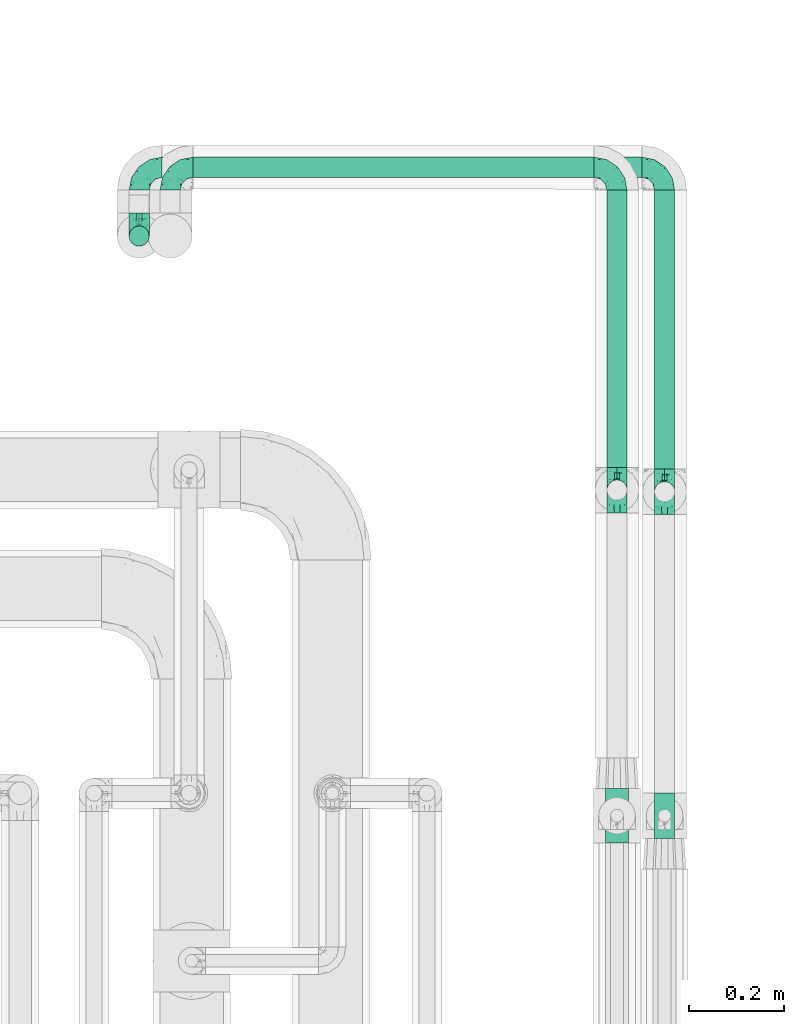
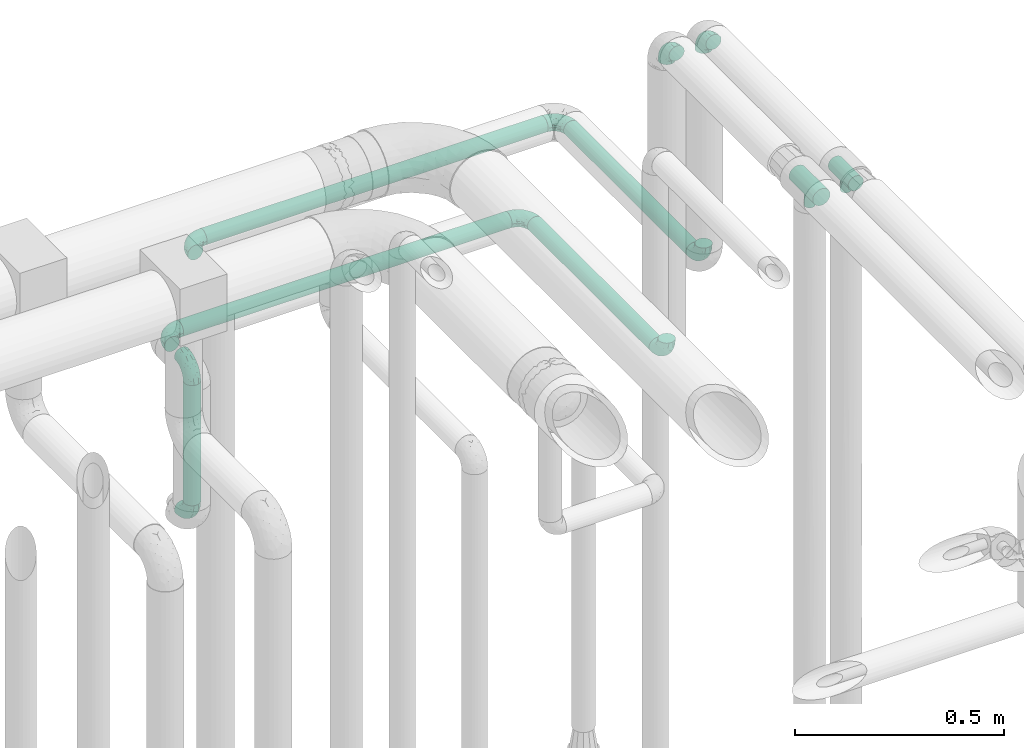
# One storey, part 727 of 827: 12 flow fittings, 5 flow segments.
"""IFC2X3 building model written with IfcOpenShell, lengths in millimetres."""

from ifc_helpers import new_model, entity, si_unit, converted_unit, derived_unit, direction, frame, origin, origin_2d_with_axis, place, context, subcontext, project, spatial, circle, extrude, faceted_brep, source, transform, mapped, material, type_object, type_shapes, element, save


model = new_model("IFC2X3")

# Units and contexts
model_context = context("Model", 3, precision=0.01, world=origin(), true_north=direction((6.12303176911189e-17, 1.0)))
body_context = subcontext(model_context, "Body", "Model", "MODEL_VIEW")
ifc_project = project(units=[si_unit("LENGTHUNIT", "METRE", prefix="MILLI"), si_unit("AREAUNIT", "SQUARE_METRE"), si_unit("VOLUMEUNIT", "CUBIC_METRE"), converted_unit("PLANEANGLEUNIT", "DEGREE", entity("IfcRatioMeasure", 0.0174532925199433), si_unit("PLANEANGLEUNIT", "RADIAN"), dimensions=[0, 0, 0, 0, 0, 0, 0]), si_unit("MASSUNIT", "GRAM", prefix="KILO"), derived_unit("MASSDENSITYUNIT", [(si_unit("MASSUNIT", "GRAM", prefix="KILO"), 1), (si_unit("LENGTHUNIT", "METRE"), -3)]), derived_unit("MOMENTOFINERTIAUNIT", [(si_unit("LENGTHUNIT", "METRE"), 4)]), si_unit("TIMEUNIT", "SECOND"), si_unit("FREQUENCYUNIT", "HERTZ"), si_unit("THERMODYNAMICTEMPERATUREUNIT", "DEGREE_CELSIUS"), derived_unit("THERMALTRANSMITTANCEUNIT", [(si_unit("MASSUNIT", "GRAM", prefix="KILO"), 1), (si_unit("THERMODYNAMICTEMPERATUREUNIT", "KELVIN"), -1), (si_unit("TIMEUNIT", "SECOND"), -3)]), derived_unit("VOLUMETRICFLOWRATEUNIT", [(si_unit("LENGTHUNIT", "METRE"), 3), (si_unit("TIMEUNIT", "SECOND"), -1)]), derived_unit("MASSFLOWRATEUNIT", [(si_unit("MASSUNIT", "GRAM", prefix="KILO"), 1), (si_unit("TIMEUNIT", "SECOND"), -1)]), derived_unit("ROTATIONALFREQUENCYUNIT", [(si_unit("TIMEUNIT", "SECOND"), -1)]), si_unit("ELECTRICCURRENTUNIT", "AMPERE"), si_unit("ELECTRICVOLTAGEUNIT", "VOLT"), si_unit("POWERUNIT", "WATT"), si_unit("FORCEUNIT", "NEWTON", prefix="KILO"), si_unit("ILLUMINANCEUNIT", "LUX"), si_unit("LUMINOUSFLUXUNIT", "LUMEN"), si_unit("LUMINOUSINTENSITYUNIT", "CANDELA"), derived_unit("USERDEFINED", [(si_unit("MASSUNIT", "GRAM", prefix="KILO"), -1), (si_unit("LENGTHUNIT", "METRE"), -2), (si_unit("TIMEUNIT", "SECOND"), 3), (si_unit("LUMINOUSFLUXUNIT", "LUMEN"), 1)]), derived_unit("LINEARVELOCITYUNIT", [(si_unit("LENGTHUNIT", "METRE"), 1), (si_unit("TIMEUNIT", "SECOND"), -1)]), si_unit("PRESSUREUNIT", "PASCAL"), derived_unit("USERDEFINED", [(si_unit("LENGTHUNIT", "METRE"), -2), (si_unit("MASSUNIT", "GRAM", prefix="KILO"), 1), (si_unit("TIMEUNIT", "SECOND"), -2)]), derived_unit("LINEARFORCEUNIT", [(si_unit("MASSUNIT", "GRAM", prefix="KILO"), 1), (si_unit("LENGTHUNIT", "METRE"), 1), (si_unit("TIMEUNIT", "SECOND"), -2), (si_unit("LENGTHUNIT", "METRE"), -1)]), derived_unit("PLANARFORCEUNIT", [(si_unit("MASSUNIT", "GRAM", prefix="KILO"), 1), (si_unit("LENGTHUNIT", "METRE"), 1), (si_unit("TIMEUNIT", "SECOND"), -2), (si_unit("LENGTHUNIT", "METRE"), -2)])], contexts=[model_context])

# Site, building, storey
site_placement = place(None, origin())
site = spatial("IfcSite", under=ifc_project, at=site_placement, CompositionType="ELEMENT")
building_placement = place(site_placement, origin())
building = spatial("IfcBuilding", under=site, at=building_placement, CompositionType="ELEMENT")
storey_placement = place(building_placement, frame((0.0, 0.0, 28200.0)))
storey = spatial("IfcBuildingStorey", under=building, at=storey_placement, Name="08", CompositionType="ELEMENT", Elevation=28200.0)

# Flow segments
pipe_segment_type = type_object("IfcPipeSegmentType", PredefinedType="NOTDEFINED")
flow_segment_1_placement = place(storey_placement, frame((60025.43, 18648.72, 1689.87)))
element("IfcFlowSegment", 1, at=flow_segment_1_placement, inside=storey, type_object=pipe_segment_type, context=body_context, shape_type="SweptSolid", body=[
    extrude(circle(Radius=21.15, at=origin_2d_with_axis()), frame((22.75, 22.75, 0.0), z_axis=(0.0, 0.0, 1.0), x_axis=(-1.0, 0.0, 0.0)), (0.0, 0.0, 1.0), 351.500000000011),
])
flow_segment_2_placement = place(storey_placement, frame((61029.89, 18185.33, 2066.63)))
element("IfcFlowSegment", 2, at=flow_segment_2_placement, inside=storey, type_object=pipe_segment_type, context=body_context, shape_type="SweptSolid", body=[
    extrude(circle(Radius=21.15, at=origin_2d_with_axis()), frame((22.75, 0.0, 22.75), z_axis=(0.0, 1.0, 0.0), x_axis=(1.0, 0.0, 0.0)), (0.0, 0.0, 1.0), 582.616004091366),
])
flow_segment_3_placement = place(storey_placement, frame((60161.17, 18793.35, 2312.0)))
element("IfcFlowSegment", 3, at=flow_segment_3_placement, inside=storey, type_object=pipe_segment_type, context=body_context, shape_type="SweptSolid", body=[
    extrude(circle(Radius=21.15, at=origin_2d_with_axis()), frame((0.0, 22.75, 22.75), z_axis=(1.0, 0.0, 0.0), x_axis=(0.0, 1.0, 0.0)), (0.0, 0.0, 1.0), 943.465172144308),
])
flow_segment_4_placement = place(storey_placement, frame((60096.17, 18793.2, 2066.63)))
element("IfcFlowSegment", 4, at=flow_segment_4_placement, inside=storey, type_object=pipe_segment_type, context=body_context, shape_type="SweptSolid", body=[
    extrude(circle(Radius=21.15, at=origin_2d_with_axis()), frame((0.0, 22.89, 22.75), z_axis=(0.999999986826571, -0.000162317151743365, 0.0), x_axis=(0.000162317151743365, 0.999999986826571, 0.0)), (0.0, 0.0, 1.0), 908.465194111927),
])
flow_segment_5_placement = place(storey_placement, frame((61129.89, 18181.83, 2312.0)))
element("IfcFlowSegment", 5, at=flow_segment_5_placement, inside=storey, type_object=pipe_segment_type, context=body_context, shape_type="SweptSolid", body=[
    extrude(circle(Radius=21.15, at=origin_2d_with_axis()), frame((22.75, 0.0, 22.75), z_axis=(0.0, 1.0, 0.0), x_axis=(1.0, 0.0, 0.0)), (0.0, 0.0, 1.0), 586.263463574079),
])

# Flow fittings
ifc_material = material()
pipe_fitting_type_1 = type_object("IfcPipeFittingType", Name="ADSK_1", PredefinedType="NOTDEFINED", material=ifc_material)
shared_shape_1 = source(origin(), body_context, "Body", "Brep", [
    faceted_brep([(-48.0, 10.6, -18.36), (-48.0, 5.49, -20.48), (-48.0, 0.0, -21.2), (-48.0, -5.49, -20.48), (-48.0, -10.6, -18.36), (-48.0, -14.99, -14.99), (-48.0, -18.36, -10.6), (-48.0, -20.48, -5.49), (-48.0, -21.2, 0.0), (-48.0, -20.48, 5.49), (-48.0, -18.36, 10.6), (-48.0, -14.99, 14.99), (-48.0, -10.6, 18.36), (-48.0, -5.49, 20.48), (-48.0, 0.0, 21.2), (-48.0, 5.49, 20.48), (-48.0, 10.6, 18.36), (-48.0, 14.99, 14.99), (-48.0, 18.36, 10.6), (-48.0, 20.48, 5.49), (-48.0, 21.2, 0.0), (-48.0, 20.48, -5.49), (-48.0, 18.36, -10.6), (-48.0, 14.99, -14.99), (0.0, 48.0, -21.2), (-5.49, 48.0, -20.48), (-10.6, 48.0, -18.36), (-14.99, 48.0, -14.99), (-18.36, 48.0, -10.6), (-20.48, 48.0, -5.49), (-21.2, 48.0, 0.0), (-20.48, 48.0, 5.49), (-18.36, 48.0, 10.6), (-14.99, 48.0, 14.99), (-10.6, 48.0, 18.36), (-5.49, 48.0, 20.48), (0.0, 48.0, 21.2), (5.49, 48.0, 20.48), (10.6, 48.0, 18.36), (14.99, 48.0, 14.99), (18.36, 48.0, 10.6), (20.48, 48.0, 5.49), (21.2, 48.0, 0.0), (20.48, 48.0, -5.49), (18.36, 48.0, -10.6), (14.99, 48.0, -14.99), (10.6, 48.0, -18.36), (5.49, 48.0, -20.48), (-35.25, -16.22, 12.01), (-34.76, -18.57, 0.0), (-20.87, -12.37, 10.9), (-31.49, -11.78, 15.9), (-37.0, -2.58, 20.86), (-33.89, 3.62, 21.15), (-31.81, -18.14, 6.76), (-5.78, 5.78, 17.67), (-19.42, -4.1, 17.86), (-9.6, -3.39, 13.73), (-35.44, -7.73, 19.13), (11.78, 31.49, 15.9), (-5.93, -5.46, 6.95), (-18.45, -13.78, 5.46), (-10.29, -8.43, 0.0), (-24.6, 0.55, 20.62), (-37.28, 17.94, 13.81), (-33.38, 22.85, 9.59), (-41.46, 20.06, 8.75), (-29.51, 20.45, 15.16), (-15.04, 10.79, 21.13), (-7.08, 16.98, 20.93), (-8.39, 23.51, 21.15), (-40.86, 13.03, 17.26), (-8.05, 41.26, 19.83), (-3.21, 35.97, 21.14), (8.53, 19.66, 14.74), (4.1, 19.42, 17.86), (-37.72, 22.66, 4.78), (-37.07, 8.58, 19.98), (-13.0, 5.43, 19.97), (-3.78, 13.93, 19.7), (3.02, 8.69, 13.43), (-2.27, -0.05, 10.65), (6.22, 6.99, 7.09), (-22.25, 34.6, 9.45), (18.14, 31.81, 6.76), (16.22, 35.25, 12.01), (12.37, 20.87, 10.9), (7.73, 35.44, 19.13), (-21.52, -15.93, 0.0), (2.58, 37.0, 20.86), (18.57, 34.76, 0.0), (13.78, 18.45, 5.46), (15.93, 21.52, 0.0), (-20.03, -8.54, 14.9), (-28.6, 28.6, 5.16), (-24.79, 34.6, 0.0), (-34.6, 24.79, 0.0), (-22.81, 37.41, 4.68), (-23.36, 26.33, 14.79), (-13.68, 37.05, 17.49), (-17.72, 38.12, 13.73), (-26.25, 27.3, 11.24), (-9.71, 32.34, 20.14), (-17.26, 25.6, 18.71), (-26.33, 9.99, 20.77), (-24.06, 6.05, 21.2), (-25.02, 15.46, 19.56), (-24.3, 20.72, 17.57), (-31.95, 15.23, 17.8), (-13.53, 24.7, 20.21), (-17.6, 17.6, 20.6), (-0.55, 24.6, 20.62), (-11.41, -7.48, 10.43), (0.93, -0.93, 0.0), (8.43, 10.29, 0.0), (-11.41, -7.48, -10.43), (-20.1, -8.84, -14.66), (-9.6, -3.39, -13.73), (7.73, 35.44, -19.13), (4.1, 19.42, -17.86), (-0.55, 24.6, -20.62), (-38.12, 17.72, -13.73), (-37.05, 13.68, -17.49), (-32.34, 9.71, -20.14), (-41.26, 8.05, -19.83), (-37.41, 22.81, -4.68), (-23.51, 8.39, -21.15), (-35.97, 3.21, -21.14), (-28.6, 28.6, -5.16), (-31.81, -18.14, -6.76), (-18.45, -13.78, -5.46), (-25.6, 17.26, -18.71), (-19.42, -4.1, -17.86), (-17.94, 37.28, -13.81), (-22.85, 33.38, -9.59), (-20.06, 41.46, -8.75), (-31.49, -11.78, -15.9), (-35.25, -16.22, -12.01), (8.53, 19.66, -14.74), (11.78, 31.49, -15.9), (-9.99, 26.33, -20.77), (-6.05, 24.06, -21.2), (-10.79, 15.04, -21.13), (-37.0, -2.58, -20.86), (-16.98, 7.08, -20.93), (-5.43, 13.0, -19.97), (-13.93, 3.78, -19.7), (-20.87, -12.37, -10.9), (-26.33, 23.36, -14.79), (-22.66, 37.72, -4.78), (13.78, 18.45, -5.46), (18.14, 31.81, -6.76), (-15.46, 25.02, -19.56), (-20.72, 24.3, -17.57), (16.22, 35.25, -12.01), (-13.03, 40.86, -17.26), (-8.58, 37.07, -19.98), (2.58, 37.0, -20.86), (-3.62, 33.89, -21.15), (-34.6, 22.25, -9.45), (6.22, 6.99, -7.09), (-20.45, 29.51, -15.16), (-35.44, -7.73, -19.13), (12.37, 20.87, -10.9), (-27.3, 26.25, -11.24), (-15.23, 31.95, -17.8), (-24.7, 13.53, -20.21), (-24.6, 0.55, -20.62), (-5.78, 5.78, -17.67), (-17.6, 17.6, -20.6), (3.02, 8.69, -13.43), (-5.93, -5.46, -6.95), (-2.27, -0.05, -10.65)], [[[0, 1, 2, 3, 4, 5, 6, 7, 8, 9, 10, 11, 12, 13, 14, 15, 16, 17, 18, 19, 20, 21, 22, 23]], [[24, 25, 26, 27, 28, 29, 30, 31, 32, 33, 34, 35, 36, 37, 38, 39, 40, 41, 42, 43, 44, 45, 46, 47]], [[10, 48, 11]], [[9, 8, 49]], [[48, 50, 51]], [[14, 52, 53]], [[10, 54, 48]], [[9, 54, 10]], [[55, 56, 57]], [[51, 12, 11]], [[51, 58, 12]], [[59, 39, 38]], [[60, 61, 62]], [[58, 56, 63]], [[64, 65, 66]], [[67, 65, 64]], [[68, 69, 70]], [[16, 71, 17]], [[13, 52, 14]], [[35, 72, 73]], [[14, 53, 15]], [[17, 64, 18]], [[74, 59, 75]], [[20, 19, 76]], [[66, 19, 18]], [[77, 15, 53]], [[15, 77, 16]], [[69, 78, 79]], [[80, 81, 82]], [[32, 31, 83]], [[84, 85, 86]], [[59, 87, 75]], [[61, 54, 88]], [[36, 89, 37]], [[84, 41, 40]], [[36, 35, 73]], [[90, 41, 84]], [[40, 39, 85]], [[12, 58, 13]], [[85, 84, 40]], [[91, 84, 86]], [[84, 92, 90]], [[87, 38, 37]], [[93, 56, 51]], [[65, 94, 76]], [[94, 95, 96]], [[84, 91, 92]], [[95, 97, 30]], [[98, 99, 100]], [[76, 94, 96]], [[101, 98, 83]], [[100, 99, 33]], [[102, 70, 73]], [[103, 102, 99]], [[94, 97, 95]], [[72, 99, 102]], [[72, 35, 34]], [[34, 33, 99]], [[9, 49, 54]], [[87, 59, 38]], [[104, 105, 68]], [[106, 103, 107]], [[106, 77, 104]], [[71, 64, 17]], [[108, 107, 67]], [[33, 32, 100]], [[109, 103, 110]], [[102, 109, 70]], [[89, 73, 111]], [[50, 48, 54]], [[51, 11, 48]], [[56, 58, 51]], [[88, 54, 49]], [[52, 58, 63]], [[50, 112, 93]], [[56, 55, 78]], [[39, 59, 85]], [[86, 85, 59]], [[89, 87, 37]], [[42, 41, 90]], [[111, 79, 75]], [[111, 75, 87]], [[75, 55, 80]], [[104, 77, 53]], [[71, 77, 108]], [[32, 83, 100]], [[98, 100, 83]], [[99, 98, 103]], [[106, 107, 108]], [[68, 70, 110]], [[111, 73, 70]], [[68, 110, 104]], [[68, 63, 78]], [[57, 93, 112]], [[80, 55, 57]], [[61, 50, 54]], [[80, 82, 86]], [[81, 57, 112]], [[74, 86, 59]], [[60, 113, 82]], [[82, 114, 91]], [[101, 94, 65]], [[97, 94, 83]], [[73, 89, 36]], [[87, 89, 111]], [[58, 52, 13]], [[53, 52, 63]], [[104, 53, 105]], [[106, 104, 110]], [[20, 76, 96]], [[76, 19, 66]], [[103, 106, 110]], [[77, 106, 108]], [[103, 98, 107]], [[67, 107, 98]], [[67, 98, 101]], [[108, 67, 64]], [[53, 63, 105]], [[63, 68, 105]], [[83, 31, 97]], [[30, 97, 31]], [[62, 113, 60]], [[112, 61, 60]], [[61, 88, 62]], [[86, 82, 91]], [[56, 78, 63]], [[114, 82, 113]], [[114, 92, 91]], [[79, 78, 55]], [[75, 79, 55]], [[69, 79, 111]], [[70, 69, 111]], [[78, 69, 68]], [[77, 71, 16]], [[64, 71, 108]], [[64, 66, 18]], [[76, 66, 65]], [[99, 72, 34]], [[73, 72, 102]], [[94, 101, 83]], [[67, 101, 65]], [[75, 80, 74]], [[80, 86, 74]], [[70, 109, 110]], [[102, 103, 109]], [[50, 93, 51]], [[57, 56, 93]], [[61, 112, 50]], [[81, 112, 60]], [[82, 81, 60]], [[80, 57, 81]], [[115, 116, 117]], [[118, 119, 120]], [[121, 122, 23]], [[123, 124, 122]], [[96, 125, 20]], [[123, 126, 127]], [[128, 96, 95]], [[129, 130, 88]], [[123, 122, 131]], [[116, 132, 117]], [[133, 134, 135]], [[0, 124, 1]], [[5, 136, 137]], [[138, 119, 139]], [[129, 88, 49]], [[140, 141, 142]], [[6, 5, 137]], [[46, 118, 47]], [[143, 3, 2]], [[144, 145, 146]], [[6, 129, 7]], [[129, 137, 147]], [[127, 2, 1]], [[148, 122, 121]], [[128, 125, 96]], [[134, 128, 149]], [[95, 149, 128]], [[150, 151, 92]], [[30, 29, 149]], [[152, 131, 153]], [[27, 133, 28]], [[154, 45, 44]], [[136, 5, 4]], [[27, 26, 155]], [[156, 26, 25]], [[24, 157, 158]], [[24, 47, 157]], [[22, 21, 159]], [[160, 150, 114]], [[134, 133, 161]], [[142, 144, 126]], [[46, 139, 118]], [[162, 136, 4]], [[156, 25, 158]], [[1, 124, 127]], [[115, 147, 116]], [[45, 154, 139]], [[139, 46, 45]], [[154, 163, 139]], [[162, 4, 3]], [[42, 90, 43]], [[130, 129, 147]], [[49, 7, 129]], [[43, 151, 44]], [[0, 23, 122]], [[24, 158, 25]], [[136, 162, 132]], [[135, 29, 28]], [[43, 90, 151]], [[164, 148, 159]], [[152, 156, 140]], [[155, 133, 27]], [[165, 153, 161]], [[23, 22, 121]], [[123, 131, 166]], [[123, 166, 126]], [[143, 127, 167]], [[147, 137, 136]], [[8, 7, 49]], [[129, 6, 137]], [[143, 162, 3]], [[167, 146, 132]], [[167, 132, 162]], [[132, 168, 117]], [[44, 151, 154]], [[92, 151, 90]], [[163, 154, 151]], [[119, 118, 139]], [[157, 118, 120]], [[138, 139, 163]], [[119, 168, 145]], [[140, 156, 158]], [[155, 156, 165]], [[22, 159, 121]], [[148, 121, 159]], [[122, 148, 131]], [[152, 153, 165]], [[142, 126, 169]], [[167, 127, 126]], [[142, 169, 140]], [[142, 120, 145]], [[168, 170, 117]], [[160, 171, 172]], [[115, 172, 171]], [[171, 62, 130]], [[119, 170, 168]], [[170, 163, 160]], [[150, 163, 151]], [[113, 171, 160]], [[164, 128, 134]], [[125, 128, 159]], [[127, 143, 2]], [[162, 143, 167]], [[118, 157, 47]], [[158, 157, 120]], [[140, 158, 141]], [[152, 140, 169]], [[30, 149, 95]], [[149, 29, 135]], [[131, 152, 169]], [[156, 152, 165]], [[131, 148, 153]], [[161, 153, 148]], [[161, 148, 164]], [[165, 161, 133]], [[158, 120, 141]], [[120, 142, 141]], [[159, 21, 125]], [[20, 125, 21]], [[115, 130, 147]], [[114, 113, 160]], [[62, 171, 113]], [[62, 88, 130]], [[160, 163, 150]], [[150, 92, 114]], [[119, 145, 120]], [[146, 145, 168]], [[132, 146, 168]], [[144, 146, 167]], [[126, 144, 167]], [[145, 144, 142]], [[156, 155, 26]], [[133, 155, 165]], [[133, 135, 28]], [[149, 135, 134]], [[122, 124, 0]], [[127, 124, 123]], [[128, 164, 159]], [[161, 164, 134]], [[163, 170, 138]], [[170, 119, 138]], [[131, 169, 166]], [[126, 166, 169]], [[147, 136, 116]], [[132, 116, 136]], [[172, 115, 117]], [[130, 115, 171]], [[117, 170, 172]], [[160, 172, 170]]]),
])
type_shapes(pipe_fitting_type_1, [shared_shape_1])
for number, where, z_axis, x_axis, name in (
    (6, (60113.17, 18816.1, 2334.74), (0.0, 0.0, 1.0), (-1.0, 0.0, 0.0), "ADSK_1"),
    (7, (60048.17, 18671.47, 1641.87), (-1.0, 0.0, 0.0), (0.0, -1.0, 0.0), "ADSK_1"),
    (8, (60048.17, 18671.47, 2089.37), (-1.0, 0.0, 0.0), (0.0, 0.0, 1.0), "ADSK_1"),
    (9, (60048.17, 18816.1, 2089.37), (0.0, 0.0, 1.0), (-1.0, 0.0, 0.0), "ADSK_1"),
    (10, (61052.64, 18137.33, 2999.74), (-1.0, 0.0, 0.0), (0.0, 1.0, 0.0), "ADSK_1"),
    (11, (61052.64, 18137.33, 2089.37), (1.0, 0.0, 0.0), (0.0, 0.0, -1.0), "ADSK_1"),
    (12, (61052.64, 18815.95, 2089.37), (0.0, 0.0, 1.0), (0.0, 1.0, 0.0), "ADSK_1"),
    (13, (61152.64, 18133.83, 2999.74), (-1.0, 0.0, 0.0), (0.0, 1.0, 0.0), "ADSK_1"),
    (14, (61152.64, 18133.83, 2334.74), (1.0, 0.0, 0.0), (0.0, 0.0, -1.0), "ADSK_1"),
    (15, (61152.64, 18816.1, 2334.74), (0.0, 0.0, 1.0), (0.0, 1.0, 0.0), "ADSK_1"),
):
    element("IfcFlowFitting", number, at=place(storey_placement, frame(where, z_axis=z_axis, x_axis=x_axis)), inside=storey, type_object=pipe_fitting_type_1, material=ifc_material, Name=name, ObjectType="ADSK_1", context=body_context, shape_type="MappedRepresentation", body=[
        mapped(shared_shape_1, transform((0.0, 0.0, 0.0), scale=1.0)),
    ])
pipe_fitting_type_2 = type_object("IfcPipeFittingType", Name="ADSK_1", PredefinedType="NOTDEFINED", material=ifc_material)
shared_shape_2 = source(origin(), body_context, "Body", "Brep", [
    faceted_brep([(-48.0, 10.6, -18.36), (-48.0, 5.49, -20.48), (-48.0, 0.0, -21.2), (-48.0, -5.49, -20.48), (-48.0, -10.6, -18.36), (-48.0, -14.99, -14.99), (-48.0, -18.36, -10.6), (-48.0, -20.48, -5.49), (-48.0, -21.2, 0.0), (-48.0, -20.48, 5.49), (-48.0, -18.36, 10.6), (-48.0, -14.99, 14.99), (-48.0, -10.6, 18.36), (-48.0, -5.49, 20.48), (-48.0, 0.0, 21.2), (-48.0, 5.49, 20.48), (-48.0, 10.6, 18.36), (-48.0, 14.99, 14.99), (-48.0, 18.36, 10.6), (-48.0, 20.48, 5.49), (-48.0, 21.2, 0.0), (-48.0, 20.48, -5.49), (-48.0, 18.36, -10.6), (-48.0, 14.99, -14.99), (48.0, 0.0, -21.2), (48.0, 5.49, -20.48), (48.0, 10.6, -18.36), (48.0, 14.99, -14.99), (48.0, 18.36, -10.6), (48.0, 20.48, -5.49), (48.0, 21.2, 0.0), (48.0, 20.48, 5.49), (48.0, 18.36, 10.6), (48.0, 14.99, 14.99), (48.0, 10.6, 18.36), (48.0, 5.49, 20.48), (48.0, 0.0, 21.2), (48.0, -5.49, 20.48), (48.0, -10.6, 18.36), (48.0, -14.99, 14.99), (48.0, -18.36, 10.6), (48.0, -20.48, 5.49), (48.0, -21.2, 0.0), (48.0, -20.48, -5.49), (48.0, -18.36, -10.6), (48.0, -14.99, -14.99), (48.0, -10.6, -18.36), (48.0, -5.49, -20.48), (12.6, -20.67, 4.7), (13.03, -20.94, 2.35), (13.45, -21.2, 0.0), (10.26, -19.33, 8.7), (2.4, -16.56, 13.23), (6.78, -17.73, 11.62), (4.59, -17.15, 12.42), (-13.45, -21.2, 0.0), (-13.03, -20.94, 2.35), (-12.6, -20.67, 4.7), (-10.26, -19.34, 8.69), (-6.78, -17.74, 11.61), (-2.4, -16.56, 13.23), (0.0, -16.56, 13.23), (2.4, -16.56, -13.23), (6.78, -17.73, -11.62), (4.59, -17.15, -12.42), (10.26, -19.33, -8.7), (12.6, -20.67, -4.7), (13.03, -20.94, -2.35), (-2.4, -16.56, -13.23), (-6.78, -17.74, -11.61), (-10.26, -19.34, -8.69), (0.0, -16.56, -13.23), (-12.6, -20.67, -4.7), (-13.03, -20.94, -2.35), (3.48, -48.0, -12.99), (6.73, -48.0, -11.65), (9.51, -48.0, -9.51), (11.65, -48.0, -6.73), (12.99, -48.0, -3.48), (13.45, -48.0, 0.0), (12.99, -48.0, 3.48), (11.65, -48.0, 6.72), (9.51, -48.0, 9.51), (6.73, -48.0, 11.65), (3.48, -48.0, 12.99), (0.0, -48.0, 13.45), (-3.48, -48.0, 12.99), (-6.72, -48.0, 11.65), (-9.51, -48.0, 9.51), (-11.65, -48.0, 6.72), (-12.99, -48.0, 3.48), (-13.45, -48.0, 0.0), (-12.99, -48.0, -3.48), (-11.65, -48.0, -6.73), (-9.51, -48.0, -9.51), (-6.72, -48.0, -11.65), (-3.48, -48.0, -12.99), (0.0, -48.0, -13.45)], [[[0, 1, 2, 3, 4, 5, 6, 7, 8, 9, 10, 11, 12, 13, 14, 15, 16, 17, 18, 19, 20, 21, 22, 23]], [[24, 25, 26, 27, 28, 29, 30, 31, 32, 33, 34, 35, 36, 37, 38, 39, 40, 41, 42, 43, 44, 45, 46, 47]], [[42, 41, 48]], [[42, 48, 49, 50]], [[41, 51, 48]], [[40, 39, 52]], [[53, 51, 40]], [[40, 52, 54, 53]], [[39, 11, 52]], [[40, 51, 41]], [[8, 55, 56, 57]], [[9, 8, 57]], [[57, 58, 9]], [[59, 60, 10]], [[59, 10, 58]], [[10, 60, 11]], [[58, 10, 9]], [[11, 60, 61, 52]], [[39, 38, 12, 11]], [[14, 13, 37, 36]], [[13, 12, 38, 37]], [[15, 14, 36, 35]], [[32, 31, 19, 18]], [[17, 16, 34, 33]], [[18, 17, 33, 32]], [[35, 34, 16, 15]], [[20, 19, 31, 30]], [[29, 28, 22, 21]], [[28, 27, 23, 22]], [[30, 29, 21, 20]], [[24, 47, 3, 2]], [[25, 1, 0, 26]], [[2, 1, 25, 24]], [[26, 0, 23, 27]], [[4, 3, 47, 46]], [[46, 45, 5, 4]], [[45, 44, 62]], [[44, 63, 64, 62]], [[44, 65, 63]], [[45, 62, 5]], [[43, 42, 66]], [[66, 65, 43]], [[42, 50, 67, 66]], [[43, 65, 44]], [[68, 69, 6]], [[6, 5, 68]], [[69, 70, 6]], [[5, 62, 71, 68]], [[70, 72, 7]], [[72, 8, 7]], [[8, 72, 73, 55]], [[70, 7, 6]], [[74, 75, 76, 77, 78, 79, 80, 81, 82, 83, 84, 85, 86, 87, 88, 89, 90, 91, 92, 93, 94, 95, 96, 97]], [[85, 60, 86]], [[59, 88, 87]], [[88, 58, 89]], [[59, 87, 86]], [[56, 55, 91]], [[91, 90, 56]], [[90, 89, 57]], [[90, 57, 56]], [[58, 57, 89]], [[88, 59, 58]], [[49, 79, 50]], [[86, 60, 59]], [[85, 52, 61, 60]], [[83, 53, 54]], [[82, 53, 83]], [[48, 81, 80]], [[82, 81, 51]], [[52, 85, 84]], [[54, 52, 84]], [[83, 54, 84]], [[53, 82, 51]], [[51, 81, 48]], [[49, 48, 80]], [[79, 49, 80]], [[78, 67, 79]], [[64, 75, 74]], [[64, 63, 75]], [[78, 66, 67]], [[78, 77, 66]], [[73, 72, 92]], [[76, 65, 77]], [[67, 50, 79]], [[66, 77, 65]], [[97, 62, 74]], [[63, 65, 76]], [[74, 62, 64]], [[63, 76, 75]], [[97, 68, 71, 62]], [[69, 96, 95]], [[94, 69, 95]], [[72, 93, 92]], [[94, 93, 70]], [[68, 97, 96]], [[96, 69, 68]], [[69, 94, 70]], [[70, 93, 72]], [[91, 73, 92]], [[73, 91, 55]]]),
])
type_shapes(pipe_fitting_type_2, [shared_shape_2])
flow_fitting_1_placement = place(storey_placement, frame((61152.64, 17452.83, 2999.74), z_axis=(1.0, 0.0, 0.0), x_axis=(0.0, 1.0, 0.0)))
element("IfcFlowFitting", 16, at=flow_fitting_1_placement, inside=storey, type_object=pipe_fitting_type_2, material=ifc_material, Name="ADSK_1", ObjectType="ADSK_1", context=body_context, shape_type="MappedRepresentation", body=[
    mapped(shared_shape_2, transform((0.0, 0.0, 0.0), scale=1.0)),
])
pipe_fitting_type_3 = type_object("IfcPipeFittingType", Name="ADSK_1", PredefinedType="NOTDEFINED", material=ifc_material)
shared_shape_3 = source(origin(), body_context, "Body", "Brep", [
    faceted_brep([(-57.0, 12.07, -20.91), (-57.0, 6.25, -23.33), (-57.0, 0.0, -24.15), (-57.0, -6.25, -23.33), (-57.0, -12.08, -20.91), (-57.0, -17.08, -17.08), (-57.0, -20.91, -12.08), (-57.0, -23.33, -6.25), (-57.0, -24.15, 0.0), (-57.0, -23.33, 6.25), (-57.0, -20.91, 12.07), (-57.0, -17.08, 17.08), (-57.0, -12.08, 20.91), (-57.0, -6.25, 23.33), (-57.0, 0.0, 24.15), (-57.0, 6.25, 23.33), (-57.0, 12.07, 20.91), (-57.0, 17.08, 17.08), (-57.0, 20.91, 12.07), (-57.0, 23.33, 6.25), (-57.0, 24.15, 0.0), (-57.0, 23.33, -6.25), (-57.0, 20.91, -12.08), (-57.0, 17.08, -17.08), (57.0, 0.0, -24.15), (57.0, 6.25, -23.33), (57.0, 12.07, -20.91), (57.0, 17.08, -17.08), (57.0, 20.91, -12.08), (57.0, 23.33, -6.25), (57.0, 24.15, 0.0), (57.0, 23.33, 6.25), (57.0, 20.91, 12.07), (57.0, 17.08, 17.08), (57.0, 12.07, 20.91), (57.0, 6.25, 23.33), (57.0, 0.0, 24.15), (57.0, -6.25, 23.33), (57.0, -12.08, 20.91), (57.0, -17.08, 17.08), (57.0, -20.91, 12.07), (57.0, -23.33, 6.25), (57.0, -24.15, 0.0), (57.0, -23.33, -6.25), (57.0, -20.91, -12.08), (57.0, -17.08, -17.08), (57.0, -12.08, -20.91), (57.0, -6.25, -23.33), (12.61, -23.69, 4.67), (13.03, -23.92, 2.34), (13.45, -24.15, 0.0), (10.28, -22.54, 8.68), (2.38, -20.2, 13.24), (6.77, -21.17, 11.62), (4.58, -20.68, 12.43), (-13.45, -24.15, 0.0), (-13.03, -23.92, 2.34), (-12.61, -23.69, 4.67), (-10.28, -22.54, 8.67), (-6.77, -21.17, 11.62), (-4.58, -20.68, 12.43), (-2.38, -20.2, 13.24), (0.0, -20.2, 13.24), (2.38, -20.2, -13.24), (6.77, -21.17, -11.62), (4.58, -20.68, -12.43), (10.28, -22.54, -8.68), (12.61, -23.69, -4.67), (13.03, -23.92, -2.34), (-2.38, -20.2, -13.24), (-4.58, -20.68, -12.43), (-6.77, -21.17, -11.62), (-10.28, -22.54, -8.67), (0.0, -20.2, -13.24), (-12.61, -23.69, -4.67), (-13.03, -23.92, -2.34), (-12.99, -57.0, -3.48), (-11.65, -57.0, -6.73), (-9.51, -57.0, -9.51), (-6.72, -57.0, -11.65), (-3.48, -57.0, -12.99), (0.0, -57.0, -13.45), (3.48, -57.0, -12.99), (6.73, -57.0, -11.65), (9.51, -57.0, -9.51), (11.65, -57.0, -6.73), (12.99, -57.0, -3.48), (13.45, -57.0, 0.0), (12.99, -57.0, 3.48), (11.65, -57.0, 6.72), (9.51, -57.0, 9.51), (6.73, -57.0, 11.65), (3.48, -57.0, 12.99), (0.0, -57.0, 13.45), (-3.48, -57.0, 12.99), (-6.72, -57.0, 11.65), (-9.51, -57.0, 9.51), (-11.65, -57.0, 6.72), (-12.99, -57.0, 3.48), (-13.45, -57.0, 0.0)], [[[0, 1, 2, 3, 4, 5, 6, 7, 8, 9, 10, 11, 12, 13, 14, 15, 16, 17, 18, 19, 20, 21, 22, 23]], [[24, 25, 26, 27, 28, 29, 30, 31, 32, 33, 34, 35, 36, 37, 38, 39, 40, 41, 42, 43, 44, 45, 46, 47]], [[42, 41, 48]], [[42, 48, 49, 50]], [[41, 51, 48]], [[40, 39, 52]], [[53, 51, 40]], [[40, 52, 54, 53]], [[39, 11, 52]], [[40, 51, 41]], [[8, 55, 56, 57]], [[9, 8, 57]], [[57, 58, 9]], [[10, 59, 60, 61]], [[59, 10, 58]], [[10, 61, 11]], [[58, 10, 9]], [[11, 61, 62, 52]], [[39, 38, 12, 11]], [[14, 13, 37, 36]], [[13, 12, 38, 37]], [[15, 14, 36, 35]], [[32, 31, 19, 18]], [[17, 16, 34, 33]], [[18, 17, 33, 32]], [[35, 34, 16, 15]], [[20, 19, 31, 30]], [[29, 28, 22, 21]], [[28, 27, 23, 22]], [[30, 29, 21, 20]], [[24, 47, 3, 2]], [[1, 0, 26, 25]], [[2, 1, 25, 24]], [[27, 26, 0, 23]], [[4, 3, 47, 46]], [[46, 45, 5, 4]], [[45, 44, 63]], [[44, 64, 65, 63]], [[44, 66, 64]], [[45, 63, 5]], [[43, 42, 67]], [[67, 66, 43]], [[42, 50, 68, 67]], [[43, 66, 44]], [[6, 69, 70, 71]], [[6, 5, 69]], [[71, 72, 6]], [[5, 63, 73, 69]], [[72, 74, 7]], [[74, 8, 7]], [[8, 74, 75, 55]], [[72, 7, 6]], [[76, 77, 78, 79, 80, 81, 82, 83, 84, 85, 86, 87, 88, 89, 90, 91, 92, 93, 94, 95, 96, 97, 98, 99]], [[57, 98, 97]], [[59, 96, 95]], [[97, 96, 58]], [[91, 54, 92]], [[56, 99, 98]], [[55, 99, 56]], [[98, 57, 56]], [[58, 57, 97]], [[96, 59, 58]], [[49, 48, 88]], [[60, 59, 95]], [[94, 61, 60]], [[49, 87, 50]], [[93, 52, 62, 61]], [[91, 53, 54]], [[90, 53, 91]], [[48, 89, 88]], [[90, 89, 51]], [[52, 93, 92]], [[54, 52, 92]], [[60, 95, 94]], [[53, 90, 51]], [[51, 89, 48]], [[93, 61, 94]], [[87, 49, 88]], [[86, 68, 87]], [[81, 63, 82]], [[65, 83, 82]], [[65, 64, 83]], [[86, 67, 68]], [[67, 86, 85]], [[75, 74, 76]], [[66, 85, 84]], [[68, 50, 87]], [[67, 85, 66]], [[79, 70, 80]], [[64, 66, 84]], [[82, 63, 65]], [[64, 84, 83]], [[81, 69, 73, 63]], [[79, 71, 70]], [[78, 71, 79]], [[74, 77, 76]], [[78, 77, 72]], [[69, 81, 80]], [[70, 69, 80]], [[71, 78, 72]], [[72, 77, 74]], [[99, 75, 76]], [[75, 99, 55]]]),
])
type_shapes(pipe_fitting_type_3, [shared_shape_3])
flow_fitting_2_placement = place(storey_placement, frame((61052.64, 17452.83, 2999.74), z_axis=(1.0, 0.0, 0.0), x_axis=(0.0, 1.0, 0.0)))
element("IfcFlowFitting", 17, at=flow_fitting_2_placement, inside=storey, type_object=pipe_fitting_type_3, material=ifc_material, Name="ADSK_1", ObjectType="ADSK_1", context=body_context, shape_type="MappedRepresentation", body=[
    mapped(shared_shape_3, transform((0.0, 0.0, 0.0), scale=1.0)),
])

save(model, "model.ifc")
